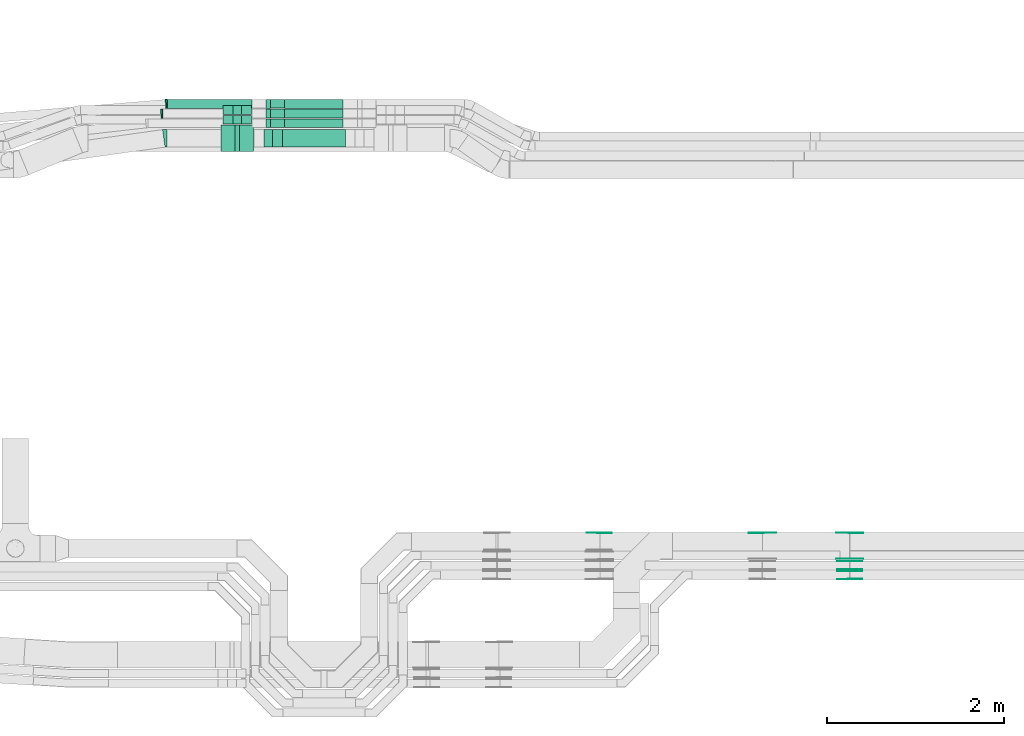
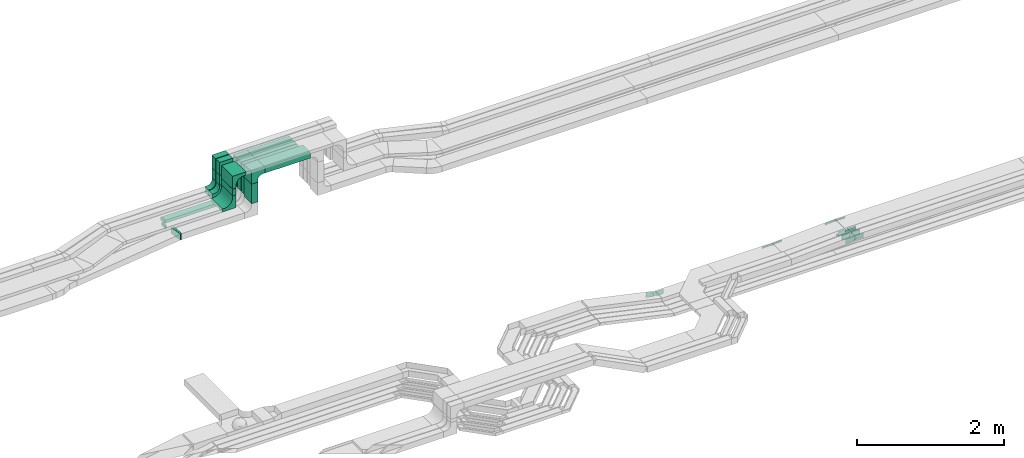
# One storey, part 16 of 32: 29 flow fittings, 12 flow segments.
"""IFC2X3 building model written with IfcOpenShell, lengths in millimetres."""

from ifc_helpers import new_model, entity, si_unit, converted_unit, derived_unit, direction, frame, frame_2d, origin, origin_2d_with_axis, place, context, subcontext, project, spatial, polyline, circle_curve, parameter, trimmed, segment, composite_curve, rectangle, outline, extrude, source, transform, mapped, material, type_object, type_shapes, element, save


model = new_model("IFC2X3")

# Units and contexts
model_context = context("Model", 3, precision=0.01, world=origin(), true_north=direction((6.12303176911189e-17, 1.0)))
body_context = subcontext(model_context, "Body", "Model", "MODEL_VIEW")
ifc_project = project(units=[si_unit("LENGTHUNIT", "METRE", prefix="MILLI"), si_unit("AREAUNIT", "SQUARE_METRE"), si_unit("VOLUMEUNIT", "CUBIC_METRE"), converted_unit("PLANEANGLEUNIT", "DEGREE", entity("IfcRatioMeasure", 0.0174532925199433), si_unit("PLANEANGLEUNIT", "RADIAN"), dimensions=[0, 0, 0, 0, 0, 0, 0]), si_unit("MASSUNIT", "GRAM", prefix="KILO"), derived_unit("MASSDENSITYUNIT", [(si_unit("MASSUNIT", "GRAM", prefix="KILO"), 1), (si_unit("LENGTHUNIT", "METRE"), -3)]), derived_unit("MOMENTOFINERTIAUNIT", [(si_unit("LENGTHUNIT", "METRE"), 4)]), si_unit("TIMEUNIT", "SECOND"), si_unit("FREQUENCYUNIT", "HERTZ"), si_unit("THERMODYNAMICTEMPERATUREUNIT", "DEGREE_CELSIUS"), derived_unit("THERMALTRANSMITTANCEUNIT", [(si_unit("MASSUNIT", "GRAM", prefix="KILO"), 1), (si_unit("THERMODYNAMICTEMPERATUREUNIT", "KELVIN"), -1), (si_unit("TIMEUNIT", "SECOND"), -3)]), derived_unit("VOLUMETRICFLOWRATEUNIT", [(si_unit("LENGTHUNIT", "METRE"), 3), (si_unit("TIMEUNIT", "SECOND"), -1)]), derived_unit("MASSFLOWRATEUNIT", [(si_unit("MASSUNIT", "GRAM", prefix="KILO"), 1), (si_unit("TIMEUNIT", "SECOND"), -1)]), derived_unit("ROTATIONALFREQUENCYUNIT", [(si_unit("TIMEUNIT", "SECOND"), -1)]), si_unit("ELECTRICCURRENTUNIT", "AMPERE"), si_unit("ELECTRICVOLTAGEUNIT", "VOLT"), si_unit("POWERUNIT", "WATT"), si_unit("FORCEUNIT", "NEWTON", prefix="KILO"), si_unit("ILLUMINANCEUNIT", "LUX"), si_unit("LUMINOUSFLUXUNIT", "LUMEN"), si_unit("LUMINOUSINTENSITYUNIT", "CANDELA"), derived_unit("USERDEFINED", [(si_unit("MASSUNIT", "GRAM", prefix="KILO"), -1), (si_unit("LENGTHUNIT", "METRE"), -2), (si_unit("TIMEUNIT", "SECOND"), 3), (si_unit("LUMINOUSFLUXUNIT", "LUMEN"), 1)]), derived_unit("LINEARVELOCITYUNIT", [(si_unit("LENGTHUNIT", "METRE"), 1), (si_unit("TIMEUNIT", "SECOND"), -1)]), si_unit("PRESSUREUNIT", "PASCAL"), derived_unit("USERDEFINED", [(si_unit("LENGTHUNIT", "METRE"), -2), (si_unit("MASSUNIT", "GRAM", prefix="KILO"), 1), (si_unit("TIMEUNIT", "SECOND"), -2)]), derived_unit("LINEARFORCEUNIT", [(si_unit("MASSUNIT", "GRAM", prefix="KILO"), 1), (si_unit("LENGTHUNIT", "METRE"), 1), (si_unit("TIMEUNIT", "SECOND"), -2), (si_unit("LENGTHUNIT", "METRE"), -1)]), derived_unit("PLANARFORCEUNIT", [(si_unit("MASSUNIT", "GRAM", prefix="KILO"), 1), (si_unit("LENGTHUNIT", "METRE"), 1), (si_unit("TIMEUNIT", "SECOND"), -2), (si_unit("LENGTHUNIT", "METRE"), -2)])], contexts=[model_context])

# Site, building, storey
site_placement = place(None, origin())
site = spatial("IfcSite", under=ifc_project, at=site_placement, CompositionType="ELEMENT")
building_placement = place(site_placement, origin())
building = spatial("IfcBuilding", under=site, at=building_placement, CompositionType="ELEMENT")
storey_placement = place(building_placement, frame((0.0, 0.0, 8100.0)))
storey = spatial("IfcBuildingStorey", under=building, at=storey_placement, CompositionType="ELEMENT", Elevation=8100.0)

# Flow segments
cable_carrier_segment_type = type_object("IfcCableCarrierSegmentType", PredefinedType="CABLETRAYSEGMENT")
flow_segment_1_placement = place(storey_placement, frame((30108.2, 14532.28, 3210.0)))
element("IfcFlowSegment", 1, at=flow_segment_1_placement, inside=storey, type_object=cable_carrier_segment_type, context=body_context, shape_type="SweptSolid", body=[
    extrude(rectangle(XDim=713.213983371323, YDim=200.000000000002, at=origin_2d_with_axis()), frame((356.61, 100.0, 0.0)), (0.0, 0.0, 1.0), 99.9999999999989),
])
flow_segment_2_placement = place(storey_placement, frame((29898.2, 14532.28, 2775.0)))
element("IfcFlowSegment", 2, at=flow_segment_2_placement, inside=storey, type_object=cable_carrier_segment_type, context=body_context, shape_type="SweptSolid", body=[
    extrude(rectangle(XDim=199.999999999998, YDim=100.000000000003, at=origin_2d_with_axis()), frame((50.0, 100.0, 0.0), z_axis=(0.0, 0.0, 1.0), x_axis=(0.0, 1.0, 0.0)), (0.0, 0.0, 1.0), 324.998679724392),
])
flow_segment_3_placement = place(storey_placement, frame((30133.2, 14750.06, 3210.0)))
element("IfcFlowSegment", 3, at=flow_segment_3_placement, inside=storey, type_object=cable_carrier_segment_type, context=body_context, shape_type="SweptSolid", body=[
    extrude(rectangle(XDim=663.2139833713, YDim=99.9999999999989, at=origin_2d_with_axis()), frame((331.61, 50.0, 0.0)), (0.0, 0.0, 1.0), 50.0000000000016),
])
flow_segment_4_placement = place(storey_placement, frame((29923.2, 14750.06, 2775.34)))
element("IfcFlowSegment", 4, at=flow_segment_4_placement, inside=storey, type_object=cable_carrier_segment_type, context=body_context, shape_type="SweptSolid", body=[
    extrude(rectangle(XDim=99.9999999999989, YDim=49.9999999999973, at=origin_2d_with_axis()), frame((25.0, 50.0, 0.0), z_axis=(0.0, 0.0, 1.0), x_axis=(0.0, 1.0, 0.0)), (0.0, 0.0, 1.0), 274.655773963117),
])
flow_segment_5_placement = place(storey_placement, frame((30133.2, 14860.06, 3210.0)))
element("IfcFlowSegment", 5, at=flow_segment_5_placement, inside=storey, type_object=cable_carrier_segment_type, context=body_context, shape_type="SweptSolid", body=[
    extrude(rectangle(XDim=663.2139833713, YDim=99.9999999999989, at=origin_2d_with_axis()), frame((331.61, 50.0, 0.0)), (0.0, 0.0, 1.0), 50.0000000000016),
])
flow_segment_6_placement = place(storey_placement, frame((29923.2, 14860.06, 2780.0)))
element("IfcFlowSegment", 6, at=flow_segment_6_placement, inside=storey, type_object=cable_carrier_segment_type, context=body_context, shape_type="SweptSolid", body=[
    extrude(rectangle(XDim=99.9999999999989, YDim=49.9999999999973, at=origin_2d_with_axis()), frame((25.0, 50.0, 0.0), z_axis=(0.0, 0.0, 1.0), x_axis=(0.0, 1.0, 0.0)), (0.0, 0.0, 1.0), 269.998679724392),
])
flow_segment_7_placement = place(storey_placement, frame((28807.21, 14970.06, 2570.0)))
element("IfcFlowSegment", 7, at=flow_segment_7_placement, inside=storey, type_object=cable_carrier_segment_type, context=body_context, shape_type="SweptSolid", body=[
    extrude(rectangle(XDim=955.988922105113, YDim=99.9999999999989, at=origin_2d_with_axis()), frame((477.99, 50.0, 0.0), z_axis=(0.0, 0.0, 1.0), x_axis=(-1.0, 0.0, 0.0)), (0.0, 0.0, 1.0), 50.0000000000016),
])
flow_segment_8_placement = place(storey_placement, frame((30133.2, 14970.06, 3210.0)))
element("IfcFlowSegment", 8, at=flow_segment_8_placement, inside=storey, type_object=cable_carrier_segment_type, context=body_context, shape_type="SweptSolid", body=[
    extrude(rectangle(XDim=663.2139833713, YDim=99.9999999999989, at=origin_2d_with_axis()), frame((331.61, 50.0, 0.0)), (0.0, 0.0, 1.0), 50.0000000000016),
])
flow_segment_9_placement = place(storey_placement, frame((29923.2, 14970.06, 2780.0)))
element("IfcFlowSegment", 9, at=flow_segment_9_placement, inside=storey, type_object=cable_carrier_segment_type, context=body_context, shape_type="SweptSolid", body=[
    extrude(rectangle(XDim=99.9999999999989, YDim=49.9999999999973, at=origin_2d_with_axis()), frame((25.0, 50.0, 0.0), z_axis=(0.0, 0.0, 1.0), x_axis=(0.0, 1.0, 0.0)), (0.0, 0.0, 1.0), 269.998679724392),
])
flow_segment_10_placement = place(storey_placement, frame((29548.2, 14900.06, 3050.0)))
element("IfcFlowSegment", 10, at=flow_segment_10_placement, inside=storey, type_object=cable_carrier_segment_type, context=body_context, shape_type="SweptSolid", body=[
    extrude(rectangle(XDim=99.9999999999989, YDim=100.000000000003, at=origin_2d_with_axis()), frame((50.0, 50.0, 0.0), z_axis=(0.0, 0.0, 1.0), x_axis=(0.0, 1.0, 0.0)), (0.0, 0.0, 1.0), 164.998679724396),
])
flow_segment_11_placement = place(storey_placement, frame((29548.2, 14790.06, 3050.0)))
element("IfcFlowSegment", 11, at=flow_segment_11_placement, inside=storey, type_object=cable_carrier_segment_type, context=body_context, shape_type="SweptSolid", body=[
    extrude(rectangle(XDim=99.9999999999989, YDim=100.000000000003, at=origin_2d_with_axis()), frame((50.0, 50.0, 0.0), z_axis=(0.0, 0.0, 1.0), x_axis=(0.0, 1.0, 0.0)), (0.0, 0.0, 1.0), 164.998679724392),
])
flow_segment_12_placement = place(storey_placement, frame((29573.2, 14480.06, 3050.02)))
element("IfcFlowSegment", 12, at=flow_segment_12_placement, inside=storey, type_object=cable_carrier_segment_type, context=body_context, shape_type="SweptSolid", body=[
    extrude(rectangle(XDim=300.000000000001, YDim=49.9999999999973, at=origin_2d_with_axis()), frame((25.0, 150.0, 0.0), z_axis=(0.0, 0.0, 1.0), x_axis=(0.0, 1.0, 0.0)), (0.0, 0.0, 1.0), 114.981555305564),
])

# Flow fittings
ifc_material_1 = material()
cable_carrier_fitting_type_1 = type_object("IfcCableCarrierFittingType", Name="470_DKC_S5_CDV 90 external vertical angle:-", PredefinedType="NOTDEFINED", material=ifc_material_1)
shared_shape_1 = source(origin(), body_context, "Body", "SweptSolid", [
    extrude(outline(composite_curve([segment(polyline([(65.71, 14.29), (95.71, 14.29)]), True, "CONTINUOUS"), segment(polyline([(95.71, 14.29), (95.71, 114.29)]), True, "CONTINUOUS"), segment(polyline([(95.71, 114.29), (-114.29, 114.29)]), True, "CONTINUOUS"), segment(polyline([(-114.29, 114.29), (-114.29, -95.71)]), True, "CONTINUOUS"), segment(polyline([(-114.29, -95.71), (-14.29, -95.71)]), True, "CONTINUOUS"), segment(polyline([(-14.29, -95.71), (-14.29, -65.71)]), True, "CONTINUOUS"), segment(trimmed(circle_curve(frame_2d((65.71, -65.71), x_axis=(-1.0, 0.0)), 80.0), [parameter(270.0)], [parameter(2.54444374517082e-13)], True, "PARAMETER"), False, "CONTINUOUS")], self_intersect=False)), frame((-64.29, 64.29, -99.0), z_axis=(0.0, 0.0, 1.0), x_axis=(-1.0, 0.0, 0.0)), (0.0, 0.0, 1.0), 199.0),
])
type_shapes(cable_carrier_fitting_type_1, [shared_shape_1])
flow_fitting_1_placement = place(storey_placement, frame((29948.2, 14632.28, 3260.0), z_axis=(0.0, 1.0, 0.0), x_axis=(0.0, 0.0, 1.0)))
element("IfcFlowFitting", 13, at=flow_fitting_1_placement, inside=storey, type_object=cable_carrier_fitting_type_1, material=ifc_material_1, Name="470_DKC_S5_90 external vertical angle", ObjectType="470_DKC_S5_CDV 90 external vertical angle:-", context=body_context, shape_type="MappedRepresentation", body=[
    mapped(shared_shape_1, transform((0.0, 0.0, 0.0), scale=1.0)),
])
cable_carrier_fitting_type_2 = type_object("IfcCableCarrierFittingType", Name="470_DKC_S5_CDV 90 external vertical angle:-", PredefinedType="NOTDEFINED", material=ifc_material_1)
shared_shape_2 = source(origin(), body_context, "Body", "SweptSolid", [
    extrude(outline(composite_curve([segment(polyline([(80.0, 50.0), (110.0, 50.0)]), True, "CONTINUOUS"), segment(polyline([(110.0, 50.0), (110.0, 100.0)]), True, "CONTINUOUS"), segment(polyline([(110.0, 100.0), (-100.0, 100.0)]), True, "CONTINUOUS"), segment(polyline([(-100.0, 100.0), (-100.0, -110.0)]), True, "CONTINUOUS"), segment(polyline([(-100.0, -110.0), (-50.0, -110.0)]), True, "CONTINUOUS"), segment(polyline([(-50.0, -110.0), (-50.0, -80.0)]), True, "CONTINUOUS"), segment(trimmed(circle_curve(frame_2d((80.0, -80.0), x_axis=(-1.0, 0.0)), 130.0), [parameter(270.0)], [parameter(2.54444374517082e-13)], True, "PARAMETER"), False, "CONTINUOUS")], self_intersect=False)), frame((-75.0, 75.0, -49.0), z_axis=(0.0, 0.0, 1.0), x_axis=(-1.0, 0.0, 0.0)), (0.0, 0.0, 1.0), 99.0000000000002),
])
type_shapes(cable_carrier_fitting_type_2, [shared_shape_2])
for number, where, z_axis, x_axis, name in (
    (14, (29948.2, 14800.06, 3235.0), (0.0, 1.0, 0.0), (0.0, 0.0, 1.0), "470_DKC_S5_90 external vertical angle"),
    (15, (29948.2, 14910.06, 3235.0), (0.0, 1.0, 0.0), (0.0, 0.0, 1.0), "470_DKC_S5_90 external vertical angle"),
    (16, (29948.2, 15020.06, 3235.0), (0.0, 1.0, 0.0), (0.0, 0.0, 1.0), "470_DKC_S5_90 external vertical angle"),
):
    element("IfcFlowFitting", number, at=place(storey_placement, frame(where, z_axis=z_axis, x_axis=x_axis)), inside=storey, type_object=cable_carrier_fitting_type_2, material=ifc_material_1, Name=name, ObjectType="470_DKC_S5_CDV 90 external vertical angle:-", context=body_context, shape_type="MappedRepresentation", body=[
        mapped(shared_shape_2, transform((0.0, 0.0, 0.0), scale=1.0)),
    ])
cable_carrier_fitting_type_3 = type_object("IfcCableCarrierFittingType", Name="470_DKC_S5_CDV 90 external vertical angle:-", PredefinedType="NOTDEFINED", material=ifc_material_1)
shared_shape_3 = source(origin(), body_context, "Body", "SweptSolid", [
    extrude(outline(composite_curve([segment(polyline([(65.71, 14.29), (95.71, 14.29)]), True, "CONTINUOUS"), segment(polyline([(95.71, 14.29), (95.71, 114.29)]), True, "CONTINUOUS"), segment(polyline([(95.71, 114.29), (-114.29, 114.29)]), True, "CONTINUOUS"), segment(polyline([(-114.29, 114.29), (-114.29, -95.71)]), True, "CONTINUOUS"), segment(polyline([(-114.29, -95.71), (-14.29, -95.71)]), True, "CONTINUOUS"), segment(polyline([(-14.29, -95.71), (-14.29, -65.71)]), True, "CONTINUOUS"), segment(trimmed(circle_curve(frame_2d((65.71, -65.71), x_axis=(-1.0, 0.0)), 80.0), [parameter(270.0)], [parameter(2.54444374517082e-13)], True, "PARAMETER"), False, "CONTINUOUS")], self_intersect=False)), frame((-64.29, 64.29, -49.0), z_axis=(0.0, 0.0, 1.0), x_axis=(-1.0, 0.0, 0.0)), (0.0, 0.0, 1.0), 99.0000000000002),
])
type_shapes(cable_carrier_fitting_type_3, [shared_shape_3])
for number, where, z_axis, x_axis, name in (
    (17, (29598.2, 14950.06, 3375.0), (0.0, 1.0, 0.0), (0.0, 0.0, 1.0), "470_DKC_S5_90 external vertical angle"),
    (18, (29598.2, 14840.06, 3375.0), (0.0, 1.0, 0.0), (0.0, 0.0, 1.0), "470_DKC_S5_90 external vertical angle"),
    (19, (29598.2, 14840.06, 2890.0), (0.0, 1.0, 0.0), (0.0, 0.0, -1.0), "470_DKC_S5_90 external vertical angle"),
    (20, (29598.2, 14950.06, 2890.0), (0.0, 1.0, 0.0), (0.0, 0.0, -1.0), "470_DKC_S5_90 external vertical angle"),
):
    element("IfcFlowFitting", number, at=place(storey_placement, frame(where, z_axis=z_axis, x_axis=x_axis)), inside=storey, type_object=cable_carrier_fitting_type_3, material=ifc_material_1, Name=name, ObjectType="470_DKC_S5_CDV 90 external vertical angle:-", context=body_context, shape_type="MappedRepresentation", body=[
        mapped(shared_shape_3, transform((0.0, 0.0, 0.0), scale=1.0)),
    ])
cable_carrier_fitting_type_4 = type_object("IfcCableCarrierFittingType", Name="470_DKC_S5_CDV 90 external vertical angle:-", PredefinedType="NOTDEFINED", material=ifc_material_1)
shared_shape_4 = source(origin(), body_context, "Body", "SweptSolid", [
    extrude(outline(composite_curve([segment(polyline([(80.0, 50.0), (110.0, 50.0)]), True, "CONTINUOUS"), segment(polyline([(110.0, 50.0), (110.0, 100.0)]), True, "CONTINUOUS"), segment(polyline([(110.0, 100.0), (-100.0, 100.0)]), True, "CONTINUOUS"), segment(polyline([(-100.0, 100.0), (-100.0, -110.0)]), True, "CONTINUOUS"), segment(polyline([(-100.0, -110.0), (-50.0, -110.0)]), True, "CONTINUOUS"), segment(polyline([(-50.0, -110.0), (-50.0, -80.0)]), True, "CONTINUOUS"), segment(trimmed(circle_curve(frame_2d((80.0, -80.0), x_axis=(-1.0, 0.0)), 130.0), [parameter(270.0)], [parameter(2.54444374517082e-13)], True, "PARAMETER"), False, "CONTINUOUS")], self_intersect=False)), frame((-75.0, 75.0, -149.0), z_axis=(0.0, 0.0, 1.0), x_axis=(-1.0, 0.0, 0.0)), (0.0, 0.0, 1.0), 299.0),
])
type_shapes(cable_carrier_fitting_type_4, [shared_shape_4])
for number, where, z_axis, x_axis, name in (
    (21, (29598.2, 14630.06, 3350.0), (0.0, 1.0, 0.0), (0.0, 0.0, 1.0), "470_DKC_S5_90 external vertical angle"),
    (22, (29598.2, 14630.06, 2865.02), (0.0, 1.0, 0.0), (0.0, 0.0, -1.0), "470_DKC_S5_90 external vertical angle"),
):
    element("IfcFlowFitting", number, at=place(storey_placement, frame(where, z_axis=z_axis, x_axis=x_axis)), inside=storey, type_object=cable_carrier_fitting_type_4, material=ifc_material_1, Name=name, ObjectType="470_DKC_S5_CDV 90 external vertical angle:-", context=body_context, shape_type="MappedRepresentation", body=[
        mapped(shared_shape_4, transform((0.0, 0.0, 0.0), scale=1.0)),
    ])
cable_carrier_fitting_type_5 = type_object("IfcCableCarrierFittingType", Name="470_DKC_S5_Variable Angle Elbow 0-45:-", PredefinedType="NOTDEFINED", material=ifc_material_1)
shared_shape_5 = source(origin(), body_context, "Body", "SweptSolid", [
    extrude(outline(composite_curve([segment(polyline([(-10.16, -50.44), (-9.16, -50.44)]), True, "CONTINUOUS"), segment(trimmed(circle_curve(frame_2d((-9.16, 199.56), x_axis=(0.0, -1.0)), 250.0), [parameter(0.0)], [parameter(5.25373463552036)], True, "PARAMETER"), True, "CONTINUOUS"), segment(polyline([(13.74, -49.39), (14.73, -49.3)]), True, "CONTINUOUS"), segment(polyline([(14.73, -49.3), (5.58, 50.28)]), True, "CONTINUOUS"), segment(polyline([(5.58, 50.28), (4.58, 50.19)]), True, "CONTINUOUS"), segment(trimmed(circle_curve(frame_2d((-9.16, 199.56), x_axis=(0.0, -1.0)), 150.0), [parameter(0.0)], [parameter(5.25373463552036)], True, "PARAMETER"), False, "CONTINUOUS"), segment(polyline([(-9.16, 49.56), (-10.16, 49.56)]), True, "CONTINUOUS"), segment(polyline([(-10.16, 49.56), (-10.16, -50.44)]), True, "CONTINUOUS")], self_intersect=False)), frame((-0.02, 0.44, -25.0)), (0.0, 0.0, 1.0), 50.0000000000002),
])
type_shapes(cable_carrier_fitting_type_5, [shared_shape_5])
flow_fitting_2_placement = place(storey_placement, frame((28746.8, 14910.06, 2595.0), z_axis=(0.0, 0.0, 1.0), x_axis=(-1.0, 0.0, 0.0)))
element("IfcFlowFitting", 23, at=flow_fitting_2_placement, inside=storey, type_object=cable_carrier_fitting_type_5, material=ifc_material_1, Name="470_DKC_S5_Variable Angle Elbow 0-45:-", ObjectType="470_DKC_S5_Variable Angle Elbow 0-45:-", context=body_context, shape_type="MappedRepresentation", body=[
    mapped(shared_shape_5, transform((0.0, 0.0, 0.0), scale=1.0)),
])
cable_carrier_fitting_type_6 = type_object("IfcCableCarrierFittingType", Name="470_DKC_S5_Variable Angle Elbow 0-45:-", PredefinedType="NOTDEFINED", material=ifc_material_1)
shared_shape_6 = source(origin(), body_context, "Body", "SweptSolid", [
    extrude(outline(composite_curve([segment(polyline([(-9.18, -50.36), (-8.18, -50.36)]), True, "CONTINUOUS"), segment(trimmed(circle_curve(frame_2d((-8.18, 199.64), x_axis=(0.0, -1.0)), 250.0), [parameter(0.0)], [parameter(4.69132642007995)], True, "PARAMETER"), True, "CONTINUOUS"), segment(polyline([(12.27, -49.52), (13.27, -49.44)]), True, "CONTINUOUS"), segment(polyline([(13.27, -49.44), (5.09, 50.23)]), True, "CONTINUOUS"), segment(polyline([(5.09, 50.23), (4.09, 50.15)]), True, "CONTINUOUS"), segment(trimmed(circle_curve(frame_2d((-8.18, 199.64), x_axis=(0.0, -1.0)), 150.0), [parameter(0.0)], [parameter(4.69132642007995)], True, "PARAMETER"), False, "CONTINUOUS"), segment(polyline([(-8.18, 49.64), (-9.18, 49.64)]), True, "CONTINUOUS"), segment(polyline([(-9.18, 49.64), (-9.18, -50.36)]), True, "CONTINUOUS")], self_intersect=False)), frame((-0.01, 0.36, -25.0)), (0.0, 0.0, 1.0), 50.0000000000002),
])
type_shapes(cable_carrier_fitting_type_6, [shared_shape_6])
flow_fitting_3_placement = place(storey_placement, frame((28798.02, 15020.06, 2595.0), z_axis=(0.0, 0.0, 1.0), x_axis=(-1.0, 0.0, 0.0)))
element("IfcFlowFitting", 24, at=flow_fitting_3_placement, inside=storey, type_object=cable_carrier_fitting_type_6, material=ifc_material_1, Name="470_DKC_S5_Variable Angle Elbow 0-45:-", ObjectType="470_DKC_S5_Variable Angle Elbow 0-45:-", context=body_context, shape_type="MappedRepresentation", body=[
    mapped(shared_shape_6, transform((0.0, 0.0, 0.0), scale=1.0)),
])
cable_carrier_fitting_type_7 = type_object("IfcCableCarrierFittingType", Name="470_DKC_S5_Variable Angle Elbow 0-45:-", PredefinedType="NOTDEFINED", material=ifc_material_1)
shared_shape_7 = source(origin(), body_context, "Body", "SweptSolid", [
    extrude(outline(composite_curve([segment(polyline([(-18.37, -101.25), (-17.37, -101.25)]), True, "CONTINUOUS"), segment(trimmed(circle_curve(frame_2d((-17.37, 248.75), x_axis=(0.0, -1.0)), 350.0), [parameter(0.0)], [parameter(7.99024953832981)], True, "PARAMETER"), True, "CONTINUOUS"), segment(polyline([(31.28, -97.85), (32.27, -97.71)]), True, "CONTINUOUS"), segment(polyline([(32.27, -97.71), (4.47, 100.35)]), True, "CONTINUOUS"), segment(polyline([(4.47, 100.35), (3.48, 100.21)]), True, "CONTINUOUS"), segment(trimmed(circle_curve(frame_2d((-17.37, 248.75), x_axis=(0.0, -1.0)), 150.0), [parameter(0.0)], [parameter(7.99024953832981)], True, "PARAMETER"), False, "CONTINUOUS"), segment(polyline([(-17.37, 98.75), (-18.37, 98.75)]), True, "CONTINUOUS"), segment(polyline([(-18.37, 98.75), (-18.37, -101.25)]), True, "CONTINUOUS")], self_intersect=False)), frame((-0.09, 1.25, -50.0)), (0.0, 0.0, 1.0), 100.0),
])
type_shapes(cable_carrier_fitting_type_7, [shared_shape_7])
flow_fitting_4_placement = place(storey_placement, frame((28786.72, 14632.28, 2615.0), z_axis=(0.0, -8.61527627208902e-06, 1.0), x_axis=(-1.0, 0.0, 0.0)))
element("IfcFlowFitting", 25, at=flow_fitting_4_placement, inside=storey, type_object=cable_carrier_fitting_type_7, material=ifc_material_1, Name="470_DKC_S5_Variable Angle Elbow 0-45:-", ObjectType="470_DKC_S5_Variable Angle Elbow 0-45:-", context=body_context, shape_type="MappedRepresentation", body=[
    mapped(shared_shape_7, transform((0.0, 0.0, 0.0), scale=1.0)),
])
ifc_material_2 = material(Name="G")
cable_carrier_fitting_type_8 = type_object("IfcCableCarrierFittingType", PredefinedType="NOTDEFINED", material=ifc_material_2)
shared_shape_8 = source(origin(), body_context, "Body", "SweptSolid", [
    extrude(outline(composite_curve([segment(trimmed(circle_curve(frame_2d((-44.59, 0.0), x_axis=(1.0, 0.0)), 12.5), [parameter(90.0000000000007)], [parameter(270.0)], True, "PARAMETER"), True, "CONTINUOUS"), segment(polyline([(-44.59, -12.5), (-33.09, -12.5)]), True, "CONTINUOUS"), segment(polyline([(-33.09, -12.5), (-31.23, -14.5)]), True, "CONTINUOUS"), segment(polyline([(-31.23, -14.5), (108.91, -14.5)]), True, "CONTINUOUS"), segment(polyline([(108.91, -14.5), (108.91, 14.5)]), True, "CONTINUOUS"), segment(polyline([(108.91, 14.5), (-31.23, 14.5)]), True, "CONTINUOUS"), segment(polyline([(-31.23, 14.5), (-33.09, 12.5)]), True, "CONTINUOUS"), segment(polyline([(-33.09, 12.5), (-44.59, 12.5)]), True, "CONTINUOUS")], self_intersect=False)), frame((44.59, 0.0, 0.0), z_axis=(0.0, 0.0, -1.0), x_axis=(1.0, 0.0, 0.0)), (0.0, 0.0, -1.0), 2.0),
])
type_shapes(cable_carrier_fitting_type_8, [shared_shape_8])
flow_fitting_5_placement = place(storey_placement, frame((36521.72, 9879.54, 2825.02), z_axis=(0.0, -1.0, 0.0), x_axis=(-0.998721383285711, 0.0, -0.0505529283808162)))
element("IfcFlowFitting", 26, at=flow_fitting_5_placement, inside=storey, type_object=cable_carrier_fitting_type_8, material=ifc_material_2, context=body_context, shape_type="MappedRepresentation", body=[
    mapped(shared_shape_8, transform((0.0, 0.0, 0.0), scale=1.0)),
])
cable_carrier_fitting_type_9 = type_object("IfcCableCarrierFittingType", PredefinedType="NOTDEFINED", material=ifc_material_2)
type_shapes(cable_carrier_fitting_type_9, [shared_shape_8])
for number, where, z_axis, x_axis in (
    (27, (36521.72, 10168.46, 2825.02), (0.0, 1.0, 0.0), (1.0, 0.0, 0.0)),
    (28, (35533.92, 10168.46, 2775.02), (0.0, 1.0, 0.0), (-1.0, 0.0, 0.0)),
):
    element("IfcFlowFitting", number, at=place(storey_placement, frame(where, z_axis=z_axis, x_axis=x_axis)), inside=storey, type_object=cable_carrier_fitting_type_9, material=ifc_material_2, context=body_context, shape_type="MappedRepresentation", body=[
        mapped(shared_shape_8, transform((0.0, 0.0, 0.0), scale=1.0)),
    ])
cable_carrier_fitting_type_10 = type_object("IfcCableCarrierFittingType", PredefinedType="NOTDEFINED", material=ifc_material_2)
shared_shape_9 = source(origin(), body_context, "Body", "SweptSolid", [
    extrude(outline(composite_curve([segment(trimmed(circle_curve(frame_2d((-44.59, 0.0), x_axis=(1.0, 0.0)), 12.5), [parameter(90.0000000000007)], [parameter(270.0)], True, "PARAMETER"), True, "CONTINUOUS"), segment(polyline([(-44.59, -12.5), (-33.09, -12.5)]), True, "CONTINUOUS"), segment(polyline([(-33.09, -12.5), (-31.23, -14.5)]), True, "CONTINUOUS"), segment(polyline([(-31.23, -14.5), (108.91, -14.5)]), True, "CONTINUOUS"), segment(polyline([(108.91, -14.5), (108.91, 14.5)]), True, "CONTINUOUS"), segment(polyline([(108.91, 14.5), (-31.23, 14.5)]), True, "CONTINUOUS"), segment(polyline([(-31.23, 14.5), (-33.09, 12.5)]), True, "CONTINUOUS"), segment(polyline([(-33.09, 12.5), (-44.59, 12.5)]), True, "CONTINUOUS")], self_intersect=False)), frame((44.59, 0.0, 0.0)), (0.0, 0.0, 1.0), 2.0),
])
type_shapes(cable_carrier_fitting_type_10, [shared_shape_9])
flow_fitting_6_placement = place(storey_placement, frame((36521.72, 10170.46, 2825.02), z_axis=(0.0, 1.0, 0.0), x_axis=(-0.998721383285711, 0.0, -0.0505529283808162)))
element("IfcFlowFitting", 29, at=flow_fitting_6_placement, inside=storey, type_object=cable_carrier_fitting_type_10, material=ifc_material_2, context=body_context, shape_type="MappedRepresentation", body=[
    mapped(shared_shape_9, transform((0.0, 0.0, 0.0), scale=1.0)),
])
cable_carrier_fitting_type_11 = type_object("IfcCableCarrierFittingType", PredefinedType="NOTDEFINED", material=ifc_material_2)
type_shapes(cable_carrier_fitting_type_11, [shared_shape_9])
flow_fitting_7_placement = place(storey_placement, frame((36521.72, 9881.54, 2825.02), z_axis=(0.0, -1.0, 0.0), x_axis=(1.0, 0.0, 0.0)))
element("IfcFlowFitting", 30, at=flow_fitting_7_placement, inside=storey, type_object=cable_carrier_fitting_type_11, material=ifc_material_2, context=body_context, shape_type="MappedRepresentation", body=[
    mapped(shared_shape_9, transform((0.0, 0.0, 0.0), scale=1.0)),
])
flow_fitting_8_placement = place(storey_placement, frame((35533.92, 10170.46, 2775.02), z_axis=(0.0, 1.0, 0.0), x_axis=(0.998721383285711, 0.0, 0.0505529283808162)))
element("IfcFlowFitting", 31, at=flow_fitting_8_placement, inside=storey, type_object=cable_carrier_fitting_type_10, material=ifc_material_2, context=body_context, shape_type="MappedRepresentation", body=[
    mapped(shared_shape_9, transform((0.0, 0.0, 0.0), scale=1.0)),
])
cable_carrier_fitting_type_12 = type_object("IfcCableCarrierFittingType", PredefinedType="NOTDEFINED", material=ifc_material_2)
shared_shape_10 = source(origin(), body_context, "Body", "SweptSolid", [
    extrude(outline(composite_curve([segment(trimmed(circle_curve(frame_2d((-41.47, 0.0), x_axis=(1.0, 0.0)), 25.0), [parameter(90.0000000000007)], [parameter(270.0)], True, "PARAMETER"), True, "CONTINUOUS"), segment(polyline([(-41.47, -25.0), (-29.97, -25.0)]), True, "CONTINUOUS"), segment(polyline([(-29.97, -25.0), (-28.1, -38.5)]), True, "CONTINUOUS"), segment(polyline([(-28.1, -38.5), (99.53, -38.5)]), True, "CONTINUOUS"), segment(polyline([(99.53, -38.5), (99.53, 38.5)]), True, "CONTINUOUS"), segment(polyline([(99.53, 38.5), (-28.1, 38.5)]), True, "CONTINUOUS"), segment(polyline([(-28.1, 38.5), (-29.97, 25.0)]), True, "CONTINUOUS"), segment(polyline([(-29.97, 25.0), (-41.47, 25.0)]), True, "CONTINUOUS")], self_intersect=False)), frame((41.47, 0.0, 0.0), z_axis=(0.0, 0.0, -1.0), x_axis=(1.0, 0.0, 0.0)), (0.0, 0.0, -1.0), 2.0),
])
type_shapes(cable_carrier_fitting_type_12, [shared_shape_10])
flow_fitting_9_placement = place(storey_placement, frame((36521.72, 9649.54, 2849.28), z_axis=(0.0, -1.0, 0.0), x_axis=(-0.998721383285712, 0.0, -0.0505529283807962)))
element("IfcFlowFitting", 32, at=flow_fitting_9_placement, inside=storey, type_object=cable_carrier_fitting_type_12, material=ifc_material_2, context=body_context, shape_type="MappedRepresentation", body=[
    mapped(shared_shape_10, transform((0.0, 0.0, 0.0), scale=1.0)),
])
cable_carrier_fitting_type_13 = type_object("IfcCableCarrierFittingType", PredefinedType="NOTDEFINED", material=ifc_material_2)
type_shapes(cable_carrier_fitting_type_13, [shared_shape_10])
flow_fitting_10_placement = place(storey_placement, frame((36521.72, 9738.46, 2849.28), z_axis=(0.0, 1.0, 0.0), x_axis=(1.0, 0.0, 0.0)))
element("IfcFlowFitting", 33, at=flow_fitting_10_placement, inside=storey, type_object=cable_carrier_fitting_type_13, material=ifc_material_2, context=body_context, shape_type="MappedRepresentation", body=[
    mapped(shared_shape_10, transform((0.0, 0.0, 0.0), scale=1.0)),
])
flow_fitting_11_placement = place(storey_placement, frame((36521.72, 9759.54, 2850.01), z_axis=(0.0, -1.0, 0.0), x_axis=(-0.998721383285712, 0.0, -0.0505529283807962)))
element("IfcFlowFitting", 34, at=flow_fitting_11_placement, inside=storey, type_object=cable_carrier_fitting_type_12, material=ifc_material_2, context=body_context, shape_type="MappedRepresentation", body=[
    mapped(shared_shape_10, transform((0.0, 0.0, 0.0), scale=1.0)),
])
flow_fitting_12_placement = place(storey_placement, frame((36521.72, 9848.46, 2850.01), z_axis=(0.0, 1.0, 0.0), x_axis=(1.0, 0.0, 0.0)))
element("IfcFlowFitting", 35, at=flow_fitting_12_placement, inside=storey, type_object=cable_carrier_fitting_type_13, material=ifc_material_2, context=body_context, shape_type="MappedRepresentation", body=[
    mapped(shared_shape_10, transform((0.0, 0.0, 0.0), scale=1.0)),
])
flow_fitting_13_placement = place(storey_placement, frame((33692.72, 10170.46, 2597.39), z_axis=(0.0, 1.0, 0.0), x_axis=(-0.977192506439547, 0.0, 0.212355375157765)))
element("IfcFlowFitting", 36, at=flow_fitting_13_placement, inside=storey, type_object=cable_carrier_fitting_type_12, material=ifc_material_2, context=body_context, shape_type="MappedRepresentation", body=[
    mapped(shared_shape_10, transform((0.0, 0.0, 0.0), scale=1.0)),
])
cable_carrier_fitting_type_14 = type_object("IfcCableCarrierFittingType", PredefinedType="NOTDEFINED", material=ifc_material_2)
shared_shape_11 = source(origin(), body_context, "Body", "SweptSolid", [
    extrude(outline(composite_curve([segment(trimmed(circle_curve(frame_2d((-41.47, 0.0), x_axis=(1.0, 0.0)), 25.0), [parameter(90.0000000000007)], [parameter(270.0)], True, "PARAMETER"), True, "CONTINUOUS"), segment(polyline([(-41.47, -25.0), (-29.97, -25.0)]), True, "CONTINUOUS"), segment(polyline([(-29.97, -25.0), (-28.1, -38.5)]), True, "CONTINUOUS"), segment(polyline([(-28.1, -38.5), (99.53, -38.5)]), True, "CONTINUOUS"), segment(polyline([(99.53, -38.5), (99.53, 38.5)]), True, "CONTINUOUS"), segment(polyline([(99.53, 38.5), (-28.1, 38.5)]), True, "CONTINUOUS"), segment(polyline([(-28.1, 38.5), (-29.97, 25.0)]), True, "CONTINUOUS"), segment(polyline([(-29.97, 25.0), (-41.47, 25.0)]), True, "CONTINUOUS")], self_intersect=False)), frame((41.47, 0.0, 0.0)), (0.0, 0.0, 1.0), 2.0),
])
type_shapes(cable_carrier_fitting_type_14, [shared_shape_11])
flow_fitting_14_placement = place(storey_placement, frame((36521.72, 9740.46, 2849.28), z_axis=(0.0, 1.0, 0.0), x_axis=(-0.998721383285712, 0.0, -0.0505529283807962)))
element("IfcFlowFitting", 37, at=flow_fitting_14_placement, inside=storey, type_object=cable_carrier_fitting_type_14, material=ifc_material_2, context=body_context, shape_type="MappedRepresentation", body=[
    mapped(shared_shape_11, transform((0.0, 0.0, 0.0), scale=1.0)),
])
cable_carrier_fitting_type_15 = type_object("IfcCableCarrierFittingType", PredefinedType="NOTDEFINED", material=ifc_material_2)
type_shapes(cable_carrier_fitting_type_15, [shared_shape_11])
flow_fitting_15_placement = place(storey_placement, frame((36521.72, 9651.54, 2849.28), z_axis=(0.0, -1.0, 0.0), x_axis=(1.0, 0.0, 0.0)))
element("IfcFlowFitting", 38, at=flow_fitting_15_placement, inside=storey, type_object=cable_carrier_fitting_type_15, material=ifc_material_2, context=body_context, shape_type="MappedRepresentation", body=[
    mapped(shared_shape_11, transform((0.0, 0.0, 0.0), scale=1.0)),
])
flow_fitting_16_placement = place(storey_placement, frame((36521.72, 9850.46, 2850.01), z_axis=(0.0, 1.0, 0.0), x_axis=(-0.998721383285712, 0.0, -0.0505529283807962)))
element("IfcFlowFitting", 39, at=flow_fitting_16_placement, inside=storey, type_object=cable_carrier_fitting_type_14, material=ifc_material_2, context=body_context, shape_type="MappedRepresentation", body=[
    mapped(shared_shape_11, transform((0.0, 0.0, 0.0), scale=1.0)),
])
for number, where, z_axis, x_axis in (
    (40, (36521.72, 9761.54, 2850.01), (0.0, -1.0, 0.0), (1.0, 0.0, 0.0)),
    (41, (33692.72, 10168.46, 2597.39), (0.0, 1.0, 0.0), (1.0, 0.0, 0.0)),
):
    element("IfcFlowFitting", number, at=place(storey_placement, frame(where, z_axis=z_axis, x_axis=x_axis)), inside=storey, type_object=cable_carrier_fitting_type_15, material=ifc_material_2, context=body_context, shape_type="MappedRepresentation", body=[
        mapped(shared_shape_11, transform((0.0, 0.0, 0.0), scale=1.0)),
    ])

save(model, "model.ifc")
